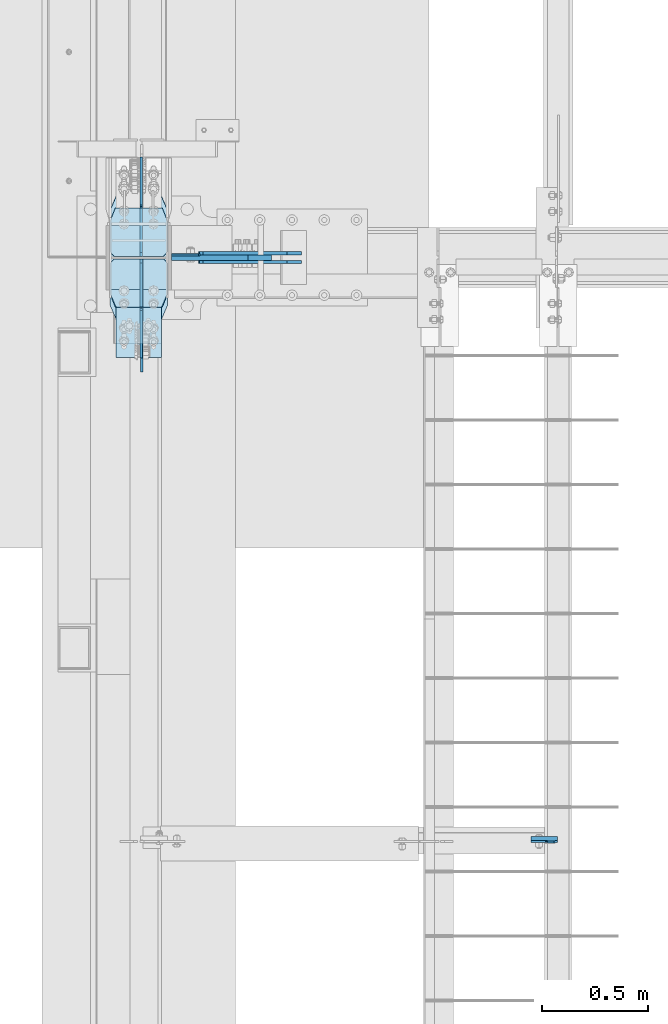
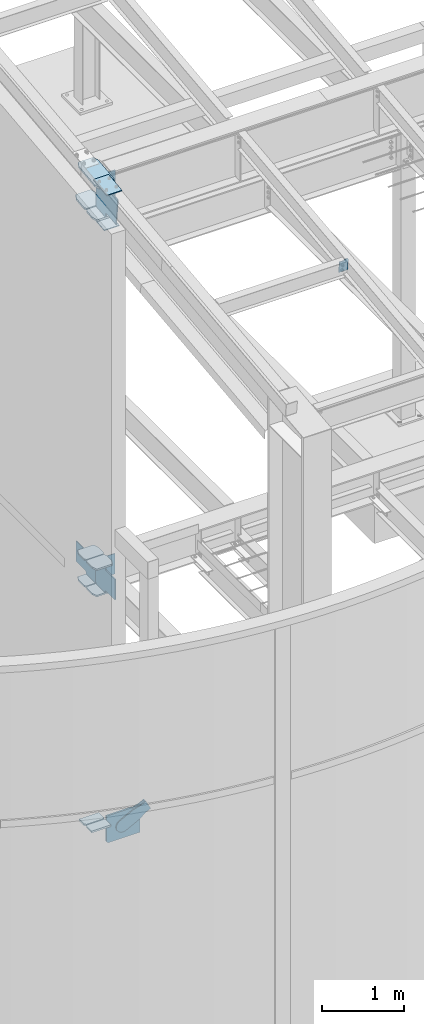
# One storey, part 984 of 1179: 20 plates, 4 elements without a shape of their own.
"""IFC2X3 building model written with IfcOpenShell, lengths in millimetres."""

from ifc_helpers import new_model, si_unit, frame, origin_with_axes, place, context, subcontext, project, spatial, faceted_brep, material, type_object, element, aggregate, save


model = new_model("IFC2X3")

# Units and contexts
model_context = context("Model", 3, precision=1e-05, world=origin_with_axes())
body_context = subcontext(model_context, "Body", "Model", "MODEL_VIEW")
ifc_project = project(units=[si_unit("LENGTHUNIT", "METRE", prefix="MILLI"), si_unit("AREAUNIT", "SQUARE_METRE"), si_unit("VOLUMEUNIT", "CUBIC_METRE"), si_unit("MASSUNIT", "GRAM", prefix="KILO"), si_unit("TIMEUNIT", "SECOND"), si_unit("PLANEANGLEUNIT", "RADIAN"), si_unit("SOLIDANGLEUNIT", "STERADIAN"), si_unit("THERMODYNAMICTEMPERATUREUNIT", "DEGREE_CELSIUS"), si_unit("LUMINOUSINTENSITYUNIT", "LUMEN")], contexts=[model_context])

# Site, building, storey
site_placement = place(None, origin_with_axes())
site = spatial("IfcSite", under=ifc_project, at=site_placement, CompositionType="ELEMENT")
building_placement = place(site_placement, origin_with_axes())
building = spatial("IfcBuilding", under=site, at=building_placement, Name="Undefined", CompositionType="ELEMENT")
storey_placement = place(building_placement, origin_with_axes())
storey = spatial("IfcBuildingStorey", under=building, at=storey_placement, Name="Undefined", CompositionType="ELEMENT", Elevation=0.0)

# Assembly, plate
assembly_1_placement = place(storey_placement, origin_with_axes())
assembly_1 = element("IfcElementAssembly", 1, at=assembly_1_placement, inside=storey, Name="BEAM", AssemblyPlace="NOTDEFINED", PredefinedType="RIGID_FRAME")
ifc_material_1 = material(Name="STEEL/A36")
plate_type_1 = type_object("IfcPlateType", PredefinedType="NOTDEFINED")
plate_1_placement = place(assembly_1_placement, frame((2410.61875, 2674.6330784409, 9544.32257560893), z_axis=(-1.0, 0.0, 0.0), x_axis=(0.0, 0.112284087038014, -0.993676146336441)))
plate_1 = element("IfcPlate", 2, at=plate_1_placement, type_object=plate_type_1, material=ifc_material_1, Name="PLATE", context=body_context, shape_type="Brep", body=[
    faceted_brep([(4.76250032839562, -4.76249999999891, 48.4187500516891), (4.76250032840471, 4.76250000000027, 48.4187500494008), (-1.45519152283669e-11, 4.76249999999345, 48.4187388288169), (-9.09494701772928e-12, -4.76249999999891, 48.4187388288169), (9.62257980372488, -4.76249999999936, 49.3854800144545), (9.62257980373579, 4.76250000000027, 49.3854800121662), (13.7427562245684, -4.76249999999845, 52.1384939244454), (13.7427562245775, 4.76250000000027, 52.1384939221571), (16.4957700889645, -4.76249999999845, 56.2586703757552), (16.4957700889754, 4.76250000000027, 56.2586703734669), (17.4624999979533, -4.76249999999845, 61.118749861791), (17.4624999979624, 4.76250000000073, 61.1187498595027), (17.462499993755, -4.76249999999845, 126.206250000661), (17.4624999937641, 4.76250000000027, 126.206250000003), (15.8749999999891, -4.76249999999845, 0.0), (-1.81898940354586e-12, -4.76249999999936, 15.875), (1.81898940354586e-12, 4.76249999999936, 15.875), (15.8749999999945, 4.76250000000027, 0.0), (185.737499999694, -4.76249999999118, 0.0), (185.737499999699, 4.76250000000755, 0.0), (185.737499999694, -4.76249999999118, 126.206250000003), (185.737499999699, 4.76250000000755, 126.206250000003)], [[[0, 1, 2, 3]], [[4, 5, 1, 0]], [[6, 7, 5, 4]], [[8, 9, 7, 6]], [[10, 11, 9, 8]], [[12, 13, 11, 10]], [[14, 15, 16, 17]], [[18, 14, 17, 19]], [[20, 18, 19, 21]], [[8, 6, 4, 0, 3, 15, 14, 18, 20, 12, 10]], [[16, 15, 3, 2]], [[21, 19, 17, 16, 2, 1, 5, 7, 9, 11, 13]], [[20, 21, 13, 12]]]),
])
aggregate(assembly_1, [plate_1])

# Assembly, plates
assembly_2_placement = place(storey_placement, origin_with_axes())
assembly_2 = element("IfcElementAssembly", 3, at=assembly_2_placement, inside=storey, Name="COLUMN", AssemblyPlace="NOTDEFINED", PredefinedType="RIGID_FRAME")
plate_2_placement = place(assembly_2_placement, frame((587.375000000002, 5446.71250000094, 4051.30000000017), z_axis=(1.0, 0.0, 0.0), x_axis=(0.0, 0.0, -1.0)))
plate_2 = element("IfcPlate", 4, at=plate_2_placement, type_object=plate_type_1, material=ifc_material_1, Name="PLATE", context=body_context, shape_type="Brep", body=[
    faceted_brep([(0.0, -4.76249999999709, 0.0), (0.0, -4.76249999999709, 127.0), (0.0, 4.76249999999709, 127.0), (0.0, 4.76249999999709, 0.0), (304.799999999999, -4.76249999999982, 127.0), (304.799999999999, 4.76249999999982, 127.0), (304.799987792969, -4.76250000000073, 0.0), (304.799987792969, 4.76250000000073, 0.0)], [[[0, 1, 2, 3]], [[2, 1, 4, 5]], [[4, 6, 7, 5]], [[6, 0, 3, 7]], [[5, 7, 3, 2]], [[6, 4, 1, 0]]]),
])
ifc_material_2 = material(Name="STEEL/A572-GR.50")
plate_type_2 = type_object("IfcPlateType", PredefinedType="NOTDEFINED")
plate_3_placement = place(assembly_2_placement, frame((569.912500000002, 5283.99420093539, 137.765030848064), z_axis=(-1.0, 0.0, 0.0), x_axis=(0.0, 1.0, 0.0)))
plate_3 = element("IfcPlate", 5, at=plate_3_placement, type_object=plate_type_2, material=ifc_material_2, Name="PLATE", context=body_context, shape_type="Brep", body=[
    faceted_brep([(0.0, -12.7, 0.0), (-3.81878635380417e-07, -12.7, 276.224999999999), (-3.81878635380417e-07, 12.7, 276.224999999999), (0.0, 12.7, 0.0), (123.824999618709, -12.7000000000002, 276.225000000001), (123.8249996187, 12.6999999999996, 276.225000000001), (146.050000000188, -12.7000000000003, 253.999999618531), (146.050000000178, 12.6999999999995, 253.999999618531), (146.050000000188, -12.7000000000003, 22.2250003814697), (146.050000000178, 12.6999999999995, 22.2250003814697), (123.824999618709, -12.7000000000002, 0.0), (123.8249996187, 12.6999999999996, 0.0)], [[[0, 1, 2, 3]], [[1, 4, 5, 2]], [[4, 6, 7, 5]], [[6, 8, 9, 7]], [[8, 10, 11, 9]], [[10, 0, 3, 11]], [[5, 7, 9, 11, 3, 2]], [[10, 8, 6, 4, 1, 0]]]),
])
plate_4_placement = place(assembly_2_placement, frame((569.912500000002, 5441.15670093552, 137.764887201485), z_axis=(-1.0, 0.0, 0.0), x_axis=(0.0, 1.0, 0.0)))
plate_4 = element("IfcPlate", 6, at=plate_4_placement, type_object=plate_type_2, material=ifc_material_2, Name="PLATE", context=body_context, shape_type="Brep", body=[
    faceted_brep([(4.54747350886464e-12, -12.6999999999999, 22.2250003814697), (4.54747350886464e-12, -12.6999999999999, 253.99999961853), (-4.54747350886464e-12, 12.6999999999999, 253.99999961853), (-4.54747350886464e-12, 12.6999999999999, 22.2250003814697), (22.2250003814834, -12.6999999999999, 276.225), (22.2250003814743, 12.6999999999998, 276.225), (146.050000000188, -12.7000000000003, 276.225), (146.050000000178, 12.6999999999995, 276.225), (146.050000000188, -12.7000000000003, 0.0), (146.050000000178, 12.6999999999995, 0.0), (22.2250003814834, -12.6999999999999, 0.0), (22.2250003814743, 12.6999999999998, 0.0)], [[[0, 1, 2, 3]], [[1, 4, 5, 2]], [[4, 6, 7, 5]], [[6, 8, 9, 7]], [[8, 10, 11, 9]], [[10, 0, 3, 11]], [[5, 7, 9, 11, 3, 2]], [[10, 8, 6, 4, 1, 0]]]),
])
plate_type_3 = type_object("IfcPlateType", PredefinedType="NOTDEFINED")
plate_5_placement = place(assembly_2_placement, frame((295.27500000019, 5142.8082926829, 9813.72370411561), z_axis=(1.0, 0.0, 0.0), x_axis=(0.0, 0.993676357192036, 0.112282221021699)))
plate_5 = element("IfcPlate", 7, at=plate_5_placement, type_object=plate_type_3, material=ifc_material_2, Name="PLATE", context=body_context, shape_type="Brep", body=[
    faceted_brep([(0.0, -14.2875000000004, 30.1625003814697), (0.0, -14.2874999999999, 242.887505722043), (0.0, 14.2874999999999, 242.887505722043), (0.0, 14.2875000000004, 30.1625003814697), (71.4375000016116, -14.2874999999858, 273.049999999798), (71.4375000016071, 14.2874999999967, 273.049999999798), (459.032977177478, -14.2875000000076, 273.049999999762), (459.03297717748, 14.2875000000167, 273.049999999762), (530.470477177256, -14.2875000000058, 242.887499618291), (530.470477177259, 14.2875000000186, 242.887499618291), (530.470477175725, -14.2875000000076, 30.1625003814613), (530.470477175728, 14.2875000000167, 30.1625003814613), (459.032977175513, -14.2875000000058, -7.27595761418343e-12), (459.032977175516, 14.2875000000167, -7.27595761418343e-12), (71.43750000002, -14.287499999984, 2.90469870378729e-11), (71.4375000000155, 14.2874999999949, 2.90469870378729e-11)], [[[0, 1, 2, 3]], [[1, 4, 5, 2]], [[4, 6, 7, 5]], [[6, 8, 9, 7]], [[8, 10, 11, 9]], [[10, 12, 13, 11]], [[12, 14, 15, 13]], [[14, 0, 3, 15]], [[5, 7, 9, 11, 13, 15, 3, 2]], [[14, 12, 10, 8, 6, 4, 1, 0]]]),
])
plate_6_placement = place(assembly_2_placement, frame((568.32499999993, 5728.41082930927, 9355.69981078858), z_axis=(-1.0, 0.0, 0.0), x_axis=(0.0, -0.993676146336441, -0.112284087038017)))
plate_6 = element("IfcPlate", 8, at=plate_6_placement, type_object=plate_type_3, material=ifc_material_2, Name="PLATE", context=body_context, shape_type="Brep", body=[
    faceted_brep([(0.0, -14.2875000000004, 30.1625003814697), (0.0, -14.2874999999999, 242.887505722043), (0.0, 14.2874999999999, 242.887505722043), (0.0, 14.2875000000004, 30.1625003814697), (71.4375000016116, -14.2874999999858, 273.049999999798), (71.4375000016071, 14.2874999999967, 273.049999999798), (265.234311050795, -14.2874999998585, 273.049999999967), (265.234311050809, 14.2875000001295, 273.049999999967), (287.459311432365, -14.2874999998457, 250.824999618502), (287.45931143238, 14.2875000001404, 250.824999618502), (287.459311433311, -14.2874999998457, 22.2250003815391), (287.459311433325, 14.2875000001404, 22.2250003815391), (265.234311051926, -14.2874999998585, 6.40056896372698e-11), (265.23431105194, 14.2875000001295, 6.40056896372698e-11), (71.43750000002, -14.287499999984, 2.90469870378729e-11), (71.4375000000155, 14.2874999999949, 2.90469870378729e-11)], [[[0, 1, 2, 3]], [[1, 4, 5, 2]], [[4, 6, 7, 5]], [[6, 8, 9, 7]], [[8, 10, 11, 9]], [[10, 12, 13, 11]], [[12, 14, 15, 13]], [[14, 0, 3, 15]], [[5, 7, 9, 11, 13, 15, 3, 2]], [[14, 12, 10, 8, 6, 4, 1, 0]]]),
])
plate_type_4 = type_object("IfcPlateType", PredefinedType="NOTDEFINED")
plate_7_placement = place(assembly_2_placement, frame((295.275000000002, 5201.44744418182, 3697.287499994), z_axis=(1.0, 0.0, 0.0), x_axis=(0.0, 1.0, 0.0)))
plate_7 = element("IfcPlate", 9, at=plate_7_placement, type_object=plate_type_4, material=ifc_material_2, Name="PLATE", context=body_context, shape_type="Brep", body=[
    faceted_brep([(0.0, -11.1125000000002, 247.650000381473), (63.5, -11.1125000000002, 273.050000000003), (63.5, 11.1125000000002, 273.050000000003), (0.0, 11.1125000000002, 247.650000381473), (63.5, -11.1125000000002, 0.0), (0.0, -11.1125000000002, 25.3999996185303), (0.0, 11.1125000000002, 25.3999996185303), (63.5, 11.1125000000002, 0.0), (206.374999618529, -11.1125000000002, 0.0), (206.374999618529, 11.1125000000002, 0.0), (228.599999999999, -11.1125000000002, 22.2250003814697), (228.599999999999, 11.1125000000002, 22.2250003814697), (228.599999999999, -11.1125000000002, 250.824999618533), (228.599999999999, 11.1125000000002, 250.824999618533), (206.374999618529, -11.1125000000002, 273.050000000003), (206.374999618529, 11.1125000000002, 273.050000000003)], [[[0, 1, 2, 3]], [[4, 5, 6, 7]], [[8, 4, 7, 9]], [[10, 8, 9, 11]], [[12, 10, 11, 13]], [[14, 12, 13, 15]], [[4, 8, 10, 12, 14, 1, 0, 5]], [[5, 0, 3, 6]], [[2, 15, 13, 11, 9, 7, 6, 3]], [[1, 14, 15, 2]]]),
])
plate_8_placement = place(assembly_2_placement, frame((295.275000000001, 5201.44780402344, 4090.98749999399), z_axis=(1.0, 0.0, 0.0), x_axis=(0.0, 1.0, 0.0)))
plate_8 = element("IfcPlate", 10, at=plate_8_placement, type_object=plate_type_4, material=ifc_material_2, Name="PLATE", context=body_context, shape_type="Brep", body=[
    faceted_brep([(0.0, -11.1125000000002, 247.650000381473), (63.5, -11.1125000000002, 273.050000000003), (63.5, 11.1125000000002, 273.050000000003), (0.0, 11.1125000000002, 247.650000381473), (63.5, -11.1125000000002, 0.0), (0.0, -11.1125000000002, 25.3999996185303), (0.0, 11.1125000000002, 25.3999996185303), (63.5, 11.1125000000002, 0.0), (206.374999618529, -11.1125000000002, 0.0), (206.374999618529, 11.1125000000002, 0.0), (228.599999999999, -11.1125000000002, 22.2250003814697), (228.599999999999, 11.1125000000002, 22.2250003814697), (228.599999999999, -11.1125000000002, 250.824999618533), (228.599999999999, 11.1125000000002, 250.824999618533), (206.374999618529, -11.1125000000002, 273.050000000003), (206.374999618529, 11.1125000000002, 273.050000000003)], [[[0, 1, 2, 3]], [[4, 5, 6, 7]], [[8, 4, 7, 9]], [[10, 8, 9, 11]], [[12, 10, 11, 13]], [[14, 12, 13, 15]], [[4, 8, 10, 12, 14, 1, 0, 5]], [[5, 0, 3, 6]], [[2, 15, 13, 11, 9, 7, 6, 3]], [[1, 14, 15, 2]]]),
])
plate_9_placement = place(assembly_2_placement, frame((568.324999999997, 5669.75996159354, 3694.1124999953), z_axis=(-1.0, 0.0, 0.0), x_axis=(0.0, -1.0, 0.0)))
plate_9 = element("IfcPlate", 11, at=plate_9_placement, type_object=plate_type_4, material=ifc_material_2, Name="PLATE", context=body_context, shape_type="Brep", body=[
    faceted_brep([(0.0, -11.1125000000002, 247.650000381473), (63.5, -11.1125000000002, 273.050000000003), (63.5, 11.1125000000002, 273.050000000003), (0.0, 11.1125000000002, 247.650000381473), (63.5, -11.1125000000002, 0.0), (0.0, -11.1125000000002, 25.3999996185303), (0.0, 11.1125000000002, 25.3999996185303), (63.5, 11.1125000000002, 0.0), (206.374999618529, -11.1125000000002, 0.0), (206.374999618529, 11.1125000000002, 0.0), (228.599999999999, -11.1125000000002, 22.2250003814697), (228.599999999999, 11.1125000000002, 22.2250003814697), (228.599999999999, -11.1125000000002, 250.824999618533), (228.599999999999, 11.1125000000002, 250.824999618533), (206.374999618529, -11.1125000000002, 273.050000000003), (206.374999618529, 11.1125000000002, 273.050000000003)], [[[0, 1, 2, 3]], [[4, 5, 6, 7]], [[8, 4, 7, 9]], [[10, 8, 9, 11]], [[12, 10, 11, 13]], [[14, 12, 13, 15]], [[4, 8, 10, 12, 14, 1, 0, 5]], [[5, 0, 3, 6]], [[2, 15, 13, 11, 9, 7, 6, 3]], [[1, 14, 15, 2]]]),
])
plate_10_placement = place(assembly_2_placement, frame((568.324999999997, 5669.76032433706, 4090.98749999505), z_axis=(-1.0, 0.0, 0.0), x_axis=(0.0, -1.0, 0.0)))
plate_10 = element("IfcPlate", 12, at=plate_10_placement, type_object=plate_type_4, material=ifc_material_2, Name="PLATE", context=body_context, shape_type="Brep", body=[
    faceted_brep([(0.0, -11.1125000000002, 247.650000381473), (63.5, -11.1125000000002, 273.050000000003), (63.5, 11.1125000000002, 273.050000000003), (0.0, 11.1125000000002, 247.650000381473), (63.5, -11.1125000000002, 0.0), (0.0, -11.1125000000002, 25.3999996185303), (0.0, 11.1125000000002, 25.3999996185303), (63.5, 11.1125000000002, 0.0), (206.374999618529, -11.1125000000002, 0.0), (206.374999618529, 11.1125000000002, 0.0), (228.599999999999, -11.1125000000002, 22.2250003814697), (228.599999999999, 11.1125000000002, 22.2250003814697), (228.599999999999, -11.1125000000002, 250.824999618533), (228.599999999999, 11.1125000000002, 250.824999618533), (206.374999618529, -11.1125000000002, 273.050000000003), (206.374999618529, 11.1125000000002, 273.050000000003)], [[[0, 1, 2, 3]], [[4, 5, 6, 7]], [[8, 4, 7, 9]], [[10, 8, 9, 11]], [[12, 10, 11, 13]], [[14, 12, 13, 15]], [[4, 8, 10, 12, 14, 1, 0, 5]], [[5, 0, 3, 6]], [[2, 15, 13, 11, 9, 7, 6, 3]], [[1, 14, 15, 2]]]),
])
plate_type_5 = type_object("IfcPlateType", PredefinedType="NOTDEFINED")
plate_11_placement = place(assembly_2_placement, frame((587.375357187497, 5448.30641762517, 9769.76628314442), z_axis=(1.0, 0.0, 0.0), x_axis=(0.0, 0.0, -1.0)))
plate_11 = element("IfcPlate", 13, at=plate_11_placement, type_object=plate_type_5, material=ifc_material_1, Name="PLATE", context=body_context, shape_type="Brep", body=[
    faceted_brep([(0.0, -6.34999999999854, 0.0), (0.0, -6.34999999999854, 133.350000000002), (0.0, 6.34999999999854, 133.350000000002), (0.0, 6.34999999999854, 0.0), (622.300000000001, -6.35000000000036, 133.350000000001), (622.300000000001, 6.35000000000036, 133.350000000001), (622.300000000001, -6.35000000000036, 0.0), (622.300000000001, 6.35000000000036, 0.0)], [[[0, 1, 2, 3]], [[1, 4, 5, 2]], [[4, 6, 7, 5]], [[6, 0, 3, 7]], [[5, 7, 3, 2]], [[6, 4, 1, 0]]]),
])
plate_type_6 = type_object("IfcPlateType", PredefinedType="NOTDEFINED")
plate_12_placement = place(assembly_2_placement, frame((323.850003068444, 4964.6084850364, 9814.28553889934), z_axis=(1.0, 0.0, 0.0), x_axis=(0.0, 0.993676146336441, 0.112284087038017)))
plate_12 = element("IfcPlate", 14, at=plate_12_placement, type_object=plate_type_6, material=ifc_material_2, Name="PLATE", context=body_context, shape_type="Brep", body=[
    faceted_brep([(0.0, -6.34999999999854, 0.0), (0.0, -6.350000000004, 215.899993896484), (0.0, 6.35000000000582, 215.899993896484), (0.0, 6.34999999999854, 0.0), (330.200000001782, -6.34999999994034, 215.899993896483), (330.200000001782, 6.35000000006767, 215.899993896483), (330.200000001782, -6.34999999994034, -1.47792889038101e-12), (330.200000001782, 6.35000000006767, -1.47792889038101e-12)], [[[0, 1, 2, 3]], [[1, 4, 5, 2]], [[4, 6, 7, 5]], [[6, 0, 3, 7]], [[5, 7, 3, 2]], [[6, 4, 1, 0]]]),
])
plate_13_placement = place(assembly_2_placement, frame((323.850003041494, 5026.9343627406, 9255.76748326321), z_axis=(1.0, 0.0, 0.0), x_axis=(0.0, 0.993676146336441, 0.112284087038017)))
plate_13 = element("IfcPlate", 15, at=plate_13_placement, type_object=plate_type_6, material=ifc_material_2, Name="PLATE", context=body_context, shape_type="Brep", body=[
    faceted_brep([(0.0, -6.34999999999854, 0.0), (0.0, -6.350000000004, 215.899993896484), (0.0, 6.35000000000582, 215.899993896484), (0.0, 6.34999999999854, 0.0), (330.200000001782, -6.34999999994034, 215.899993896483), (330.200000001782, 6.35000000006767, 215.899993896483), (330.200000001782, -6.34999999994034, -1.47792889038101e-12), (330.200000001782, 6.35000000006767, -1.47792889038101e-12)], [[[0, 1, 2, 3]], [[1, 4, 5, 2]], [[4, 6, 7, 5]], [[6, 0, 3, 7]], [[5, 7, 3, 2]], [[6, 4, 1, 0]]]),
])
plate_type_7 = type_object("IfcPlateType", PredefinedType="NOTDEFINED")
plate_14_placement = place(assembly_2_placement, frame((295.275000000183, 5201.29393468393, 9296.1368665814), z_axis=(1.0, 0.0, 0.0), x_axis=(0.0, 0.993676357192036, 0.112282221021699)))
plate_14 = element("IfcPlate", 16, at=plate_14_placement, type_object=plate_type_7, material=ifc_material_2, Name="PLATE", context=body_context, shape_type="Brep", body=[
    faceted_brep([(0.0, -14.2875000000004, 30.1625003814697), (0.0, -14.2874999999999, 242.887505722043), (0.0, 14.2874999999999, 242.887505722043), (0.0, 14.2875000000004, 30.1625003814697), (71.4375000016116, -14.2874999999858, 273.049999999798), (71.4375000016071, 14.2874999999967, 273.049999999798), (206.374999620103, -14.2874999999731, 273.049999999853), (206.374999620097, 14.2875000000076, 273.049999999853), (228.600000001447, -14.2874999999713, 250.824999618393), (228.600000001442, 14.2875000000113, 250.824999618393), (228.600000000114, -14.2874999999713, 22.2250003815627), (228.600000000108, 14.2875000000095, 22.2250003815627), (206.37499961851, -14.2874999999731, 8.39008862385526e-11), (206.374999618503, 14.2875000000095, 8.39008862385526e-11), (71.43750000002, -14.287499999984, 2.90469870378729e-11), (71.4375000000155, 14.2874999999949, 2.90469870378729e-11)], [[[0, 1, 2, 3]], [[1, 4, 5, 2]], [[4, 6, 7, 5]], [[6, 8, 9, 7]], [[8, 10, 11, 9]], [[10, 12, 13, 11]], [[12, 14, 15, 13]], [[14, 0, 3, 15]], [[5, 7, 9, 11, 13, 15, 3, 2]], [[14, 12, 10, 8, 6, 4, 1, 0]]]),
])
plate_type_8 = type_object("IfcPlateType", PredefinedType="NOTDEFINED")
plate_15_placement = place(assembly_2_placement, frame((445.293750000002, 5429.95555027375, 9355.40331321051), z_axis=(0.0, -0.743857530975871, 0.668338217978353), x_axis=(0.0, -0.668338217978354, -0.743857530975871)))
plate_15 = element("IfcPlate", 17, at=plate_15_placement, type_object=plate_type_8, material=ifc_material_2, Name="PLATE", context=body_context, shape_type="Brep", body=[
    faceted_brep([(-340.375214000167, -6.35000000000002, 305.818434893387), (-340.053041236401, -6.35000000000002, 331.102415037907), (-340.053041236401, 6.35000000000002, 331.102415037907), (-340.375214000167, 6.35000000000002, 305.818434893387), (0.0, -6.34999999999854, 0.0), (0.0, 6.34999999999854, 0.0), (28.5035613092805, -6.35000000000002, -1.04591890703887e-11), (28.5035613092805, 6.35000000000002, -1.04591890703887e-11), (187.420601399348, -6.35000000000002, 141.163452271464), (187.420601399348, 6.35000000000002, 141.163452271464), (153.121511960926, -6.35000000000002, 179.776207060837), (153.121511960926, 6.35000000000002, 179.776207060837), (148.111828553017, -6.35000000000002, 188.327179091378), (148.111828553017, 6.35000000000002, 188.327179091378), (146.755726190504, -6.35000000000002, 198.144359791408), (146.755726190504, 6.35000000000002, 198.144359791408), (149.259651370594, -6.35000000000002, 207.733228817898), (149.259651370594, 6.35000000000002, 207.733228817898), (155.242418574415, -6.35000000000002, 215.634022898216), (155.242418574415, 6.35000000000002, 215.634022898216), (325.556754792438, -6.35000000000002, 366.930663323459), (325.556754792438, 6.35000000000002, 366.930663323459), (63.9881057059411, -6.35000000000002, 661.395801413212), (63.9881057059411, 6.35000000000002, 661.395801413212), (-108.439216406068, -6.35000000000002, 508.020105830638), (-108.439216406068, 6.35000000000002, 508.020105830638), (-115.988873387907, -6.35000000000002, 503.591015810325), (-115.988873387907, 6.35000000000002, 503.591015810325), (-124.658991855624, -6.35000000000002, 502.389681257769), (-124.658991855624, 6.35000000000002, 502.389681257769), (-133.128490026194, -6.35000000000002, 504.599151712447), (-133.128490026194, 6.35000000000002, 504.599151712447), (-139.394780873125, -6.35000000000002, 509.343624777056), (-139.525108848715, -6.35000000000002, 509.227856713423), (-139.525108848715, 6.35000000000002, 509.227856713423), (-139.394780873125, 6.35000000000002, 509.343624777056)], [[[0, 1, 2, 3]], [[4, 0, 3, 5]], [[6, 4, 5, 7]], [[8, 6, 7, 9]], [[10, 8, 9, 11]], [[12, 10, 11, 13]], [[14, 12, 13, 15]], [[16, 14, 15, 17]], [[18, 16, 17, 19]], [[20, 18, 19, 21]], [[22, 20, 21, 23]], [[24, 22, 23, 25]], [[26, 24, 25, 27]], [[28, 26, 27, 29]], [[30, 28, 29, 31]], [[1, 0, 4, 6, 8, 10, 12, 14, 16, 18, 20, 22, 24, 26, 28, 30, 32, 33]], [[1, 33, 34, 2]], [[31, 29, 27, 25, 23, 21, 19, 17, 15, 13, 11, 9, 7, 5, 3, 2, 34, 35]], [[30, 31, 35, 32]], [[34, 33, 32, 35]]]),
])

# Assembly, plate
assembly_3_placement = place(storey_placement, origin_with_axes())
assembly_3 = element("IfcElementAssembly", 18, at=assembly_3_placement, inside=storey, AssemblyPlace="NOTDEFINED", PredefinedType="RIGID_FRAME")
plate_type_9 = type_object("IfcPlateType", PredefinedType="NOTDEFINED")
plate_16_placement = place(assembly_3_placement, frame((1127.36545388962, 5456.2375, 63.2880253348642), z_axis=(-0.461652125829643, 0.0, 0.88706105467266), x_axis=(0.88706105467266, 0.0, 0.461652125829643)))
plate_16 = element("IfcPlate", 19, at=plate_16_placement, type_object=plate_type_9, material=ifc_material_1, context=body_context, shape_type="Brep", body=[
    faceted_brep([(0.0, -7.9375, 0.0), (-101.600000000497, -7.9375, -21.7975798445477), (-101.600000000497, 7.9375, -21.7975798445477), (0.0, 7.9375, 0.0), (-320.921138851689, -7.9375, -21.7975798443877), (-320.921138851689, 7.9375, -21.7975798443877), (-357.371735784433, -7.9375, -14.5471053160727), (-357.371735784433, 7.9375, -14.5471053160727), (-388.273059759649, -7.9375, 6.10049924760824), (-388.273059759649, 7.9375, 6.10049924760824), (-408.920664323319, -7.9375, 37.0018232228431), (-408.920664323319, 7.9375, 37.0018232228431), (-416.171138851623, -7.9375, 73.4524201546446), (-416.171138851623, 7.9375, 73.4524201546446), (-408.920664323337, -7.9375, 109.903017087447), (-408.920664323337, 7.9375, 109.903017087447), (-388.273059759656, -7.9375, 140.804341062707), (-388.273059759656, 7.9375, 140.804341062707), (-357.3717357844, -7.9375, 161.451945626395), (-357.3717357844, 7.9375, 161.451945626395), (-320.921138851201, -7.9375, 168.702420154674), (-320.921138851201, 7.9375, 168.702420154674), (-101.600000000592, -7.9375, 168.702420154521), (-101.600000000592, 7.9375, 168.702420154521), (-8.00355337560177e-11, -7.9375, 146.904840309817), (-8.00355337560177e-11, 7.9375, 146.904840309817), (82.5499999998137, -7.9375, 146.90484031055), (82.5499999998137, 7.9375, 146.90484031055), (82.5500000000975, -7.9375, -6.91215973347425e-11), (82.5500000000975, 7.9375, -6.91215973347425e-11)], [[[0, 1, 2, 3]], [[1, 4, 5, 2]], [[4, 6, 7, 5]], [[6, 8, 9, 7]], [[8, 10, 11, 9]], [[10, 12, 13, 11]], [[12, 14, 15, 13]], [[14, 16, 17, 15]], [[16, 18, 19, 17]], [[18, 20, 21, 19]], [[20, 22, 23, 21]], [[22, 24, 25, 23]], [[24, 26, 27, 25]], [[26, 28, 29, 27]], [[28, 0, 3, 29]], [[5, 7, 9, 11, 13, 15, 17, 19, 21, 23, 25, 27, 29, 3, 2]], [[28, 26, 24, 22, 20, 18, 16, 14, 12, 10, 8, 6, 4, 1, 0]]]),
])
aggregate(assembly_3, [plate_16])

assembly_4_placement = place(storey_placement, origin_with_axes())
assembly_4 = element("IfcElementAssembly", 20, at=assembly_4_placement, inside=storey, AssemblyPlace="NOTDEFINED", PredefinedType="RIGID_FRAME")
plate_17_placement = place(assembly_4_placement, frame((1127.36545388962, 5414.9625, 63.2880253348642), z_axis=(-0.461652125829643, 0.0, 0.88706105467266), x_axis=(0.88706105467266, 0.0, 0.461652125829643)))
plate_17 = element("IfcPlate", 21, at=plate_17_placement, type_object=plate_type_9, material=ifc_material_1, context=body_context, shape_type="Brep", body=[
    faceted_brep([(0.0, -7.9375, 0.0), (-101.600000000497, -7.9375, -21.7975798445477), (-101.600000000497, 7.9375, -21.7975798445477), (0.0, 7.9375, 0.0), (-320.921138851689, -7.9375, -21.7975798443877), (-320.921138851689, 7.9375, -21.7975798443877), (-357.371735784433, -7.9375, -14.5471053160727), (-357.371735784433, 7.9375, -14.5471053160727), (-388.273059759649, -7.9375, 6.10049924760824), (-388.273059759649, 7.9375, 6.10049924760824), (-408.920664323319, -7.9375, 37.0018232228431), (-408.920664323319, 7.9375, 37.0018232228431), (-416.171138851623, -7.9375, 73.4524201546446), (-416.171138851623, 7.9375, 73.4524201546446), (-408.920664323337, -7.9375, 109.903017087447), (-408.920664323337, 7.9375, 109.903017087447), (-388.273059759656, -7.9375, 140.804341062707), (-388.273059759656, 7.9375, 140.804341062707), (-357.3717357844, -7.9375, 161.451945626395), (-357.3717357844, 7.9375, 161.451945626395), (-320.921138851201, -7.9375, 168.702420154674), (-320.921138851201, 7.9375, 168.702420154674), (-101.600000000592, -7.9375, 168.702420154521), (-101.600000000592, 7.9375, 168.702420154521), (-8.00355337560177e-11, -7.9375, 146.904840309817), (-8.00355337560177e-11, 7.9375, 146.904840309817), (82.5499999998137, -7.9375, 146.90484031055), (82.5499999998137, 7.9375, 146.90484031055), (82.5500000000975, -7.9375, -6.91215973347425e-11), (82.5500000000975, 7.9375, -6.91215973347425e-11)], [[[0, 1, 2, 3]], [[1, 4, 5, 2]], [[4, 6, 7, 5]], [[6, 8, 9, 7]], [[8, 10, 11, 9]], [[10, 12, 13, 11]], [[12, 14, 15, 13]], [[14, 16, 17, 15]], [[16, 18, 19, 17]], [[18, 20, 21, 19]], [[20, 22, 23, 21]], [[22, 24, 25, 23]], [[24, 26, 27, 25]], [[26, 28, 29, 27]], [[28, 0, 3, 29]], [[5, 7, 9, 11, 13, 15, 17, 19, 21, 23, 25, 27, 29, 3, 2]], [[28, 26, 24, 22, 20, 18, 16, 14, 12, 10, 8, 6, 4, 1, 0]]]),
])
aggregate(assembly_4, [plate_17])

# Plate
plate_type_10 = type_object("IfcPlateType", PredefinedType="NOTDEFINED")
plate_18_placement = place(assembly_2_placement, frame((587.375000000002, 5435.60013058058, -215.9), z_axis=(0.0, 0.0, 1.0), x_axis=(1.0, 0.0, 0.0)))
plate_18 = element("IfcPlate", 22, at=plate_18_placement, type_object=plate_type_10, material=ifc_material_2, Name="PLATE", context=body_context, shape_type="Brep", body=[
    faceted_brep([(0.0, -12.7000000000007, 19.0500000000029), (0.0, -12.6999999999998, 404.464866888042), (0.0, 12.6999999999998, 404.464866888042), (0.0, 12.7000000000007, 19.0500000000029), (360.257255841574, -12.6999999999998, 404.464866888021), (360.257255841574, 12.6999999999998, 404.464866888021), (471.653913804267, -12.6999999999998, 190.417034395508), (471.653913804267, 12.6999999999998, 190.417034395508), (471.653913804267, -12.6999999999998, 2.8421709430404e-14), (471.653913804267, 12.6999999999998, 2.8421709430404e-14), (19.0499992370605, -12.6999999999971, 0.0), (19.0499992370605, 12.6999999999971, 0.0)], [[[0, 1, 2, 3]], [[1, 4, 5, 2]], [[4, 6, 7, 5]], [[6, 8, 9, 7]], [[8, 10, 11, 9]], [[10, 0, 3, 11]], [[5, 7, 9, 11, 3, 2]], [[10, 8, 6, 4, 1, 0]]]),
])

plate_type_11 = type_object("IfcPlateType", PredefinedType="NOTDEFINED")
plate_19_placement = place(assembly_2_placement, frame((443.706250000002, 5430.04741179173, 3727.44999999151), z_axis=(0.0, -0.707106781186506, 0.707106781186589), x_axis=(0.0, -0.70710678118659, -0.707106781186505)))
plate_19 = element("IfcPlate", 23, at=plate_19_placement, type_object=plate_type_11, material=ifc_material_2, Name="PLATE", context=body_context, shape_type="Brep", body=[
    faceted_brep([(0.0, -6.34999999999854, 0.0), (-235.731830903293, -6.35000000000002, 235.731615453129), (-235.731830903293, 6.35000000000002, 235.731615453129), (0.0, 6.34999999999854, 0.0), (-235.731830903261, -6.35000000000002, 262.672371504901), (-235.731830903261, 6.35000000000002, 262.672371504901), (-88.1191215129029, -6.35000000000002, 410.284945982362), (-88.1191215129029, 6.35000000000002, 410.284945982362), (-85.8740474659135, -6.35000000000002, 408.039873987286), (-85.8740474659135, 6.35000000000002, 408.039873987286), (-77.6336920134536, -6.35000000000002, 402.533849952023), (-77.6336920134536, 6.35000000000002, 402.533849952023), (-67.9135320938085, -6.35000000000002, 400.600394548784), (-67.9135320938085, 6.35000000000002, 400.600394548784), (-58.1933739412743, -6.35000000000002, 402.533858835898), (-58.1933739412743, 6.35000000000002, 402.533858835898), (-49.9530235211214, -6.35000000000002, 408.039890402549), (-49.9530235211214, 6.35000000000002, 408.039890402549), (103.272773494093, -6.35000000000002, 561.265827460693), (103.272773494093, 6.35000000000002, 561.265827460693), (318.799018891273, -6.35000000000002, 345.739779046518), (318.799018891273, 6.35000000000002, 345.739779046518), (165.573221876059, -6.35000000000002, 192.513841988374), (165.573221876059, 6.35000000000002, 192.513841988374), (160.067197840795, -6.35000000000002, 184.27348653591), (160.067197840795, 6.35000000000002, 184.27348653591), (158.133742437553, -6.35000000000002, 174.55332661626), (158.133742437553, 6.35000000000002, 174.55332661626), (160.067206724663, -6.35000000000002, 164.833168463723), (160.067206724663, 6.35000000000002, 164.833168463723), (165.573238291309, -6.35000000000002, 156.592818043571), (165.573238291309, 6.35000000000002, 156.592818043571), (174.553490065037, -6.35000000000002, 147.612574477461), (174.553490065037, 6.35000000000002, 147.612574477461), (26.9407683631471, -6.34999999999854, -6.91215973347425e-11), (26.9407683631471, 6.34999999999854, -6.91215973347425e-11)], [[[0, 1, 2, 3]], [[1, 4, 5, 2]], [[4, 6, 7, 5]], [[6, 8, 9, 7]], [[8, 10, 11, 9]], [[10, 12, 13, 11]], [[12, 14, 15, 13]], [[14, 16, 17, 15]], [[16, 18, 19, 17]], [[18, 20, 21, 19]], [[20, 22, 23, 21]], [[22, 24, 25, 23]], [[24, 26, 27, 25]], [[26, 28, 29, 27]], [[28, 30, 31, 29]], [[30, 32, 33, 31]], [[32, 34, 35, 33]], [[34, 0, 3, 35]], [[5, 7, 9, 11, 13, 15, 17, 19, 21, 23, 25, 27, 29, 31, 33, 35, 3, 2]], [[34, 32, 30, 28, 26, 24, 22, 20, 18, 16, 14, 12, 10, 8, 6, 4, 1, 0]]]),
])

plate_type_12 = type_object("IfcPlateType", PredefinedType="NOTDEFINED")
plate_20_placement = place(assembly_2_placement, frame((443.706250000002, 5441.15997901061, 3724.27499998076), z_axis=(0.0, 0.707106781186542, 0.707106781186553), x_axis=(0.0, 0.707106781186553, -0.707106781186542)))
plate_20 = element("IfcPlate", 24, at=plate_20_placement, type_object=plate_type_12, material=ifc_material_2, Name="PLATE", context=body_context, shape_type="Brep", body=[
    faceted_brep([(0.0, -6.34999999999854, 0.0), (-237.976787208419, -6.34999999999854, 237.976787208414), (-237.976787208419, 6.34999999999854, 237.976787208414), (0.0, 6.34999999999854, 0.0), (-237.976787208489, -6.34999999999854, 264.917555571561), (-237.976787208489, 6.34999999999854, 264.917555571561), (-90.3638272187129, -6.35000000000002, 412.530515561223), (-90.3638272187129, 6.35000000000002, 412.530515561223), (-88.1187629187018, -6.35000000000002, 410.285451261215), (-88.1187629187018, 6.35000000000002, 410.285451261215), (-79.8784099823927, -6.35000000000002, 404.779423460262), (-79.8784099823927, 6.35000000000002, 404.779423460262), (-70.1582509462989, -6.35000000000002, 402.845963615088), (-70.1582509462989, 6.35000000000002, 402.845963615088), (-60.4380919102052, -6.35000000000002, 404.779423460268), (-60.4380919102052, 6.35000000000002, 404.779423460268), (-52.1977389738952, -6.35000000000002, 410.285451261226), (-52.1977389738952, 6.35000000000002, 410.285451261226), (100.46661535365, -6.35000000000002, 562.949805588772), (100.46661535365, 6.35000000000002, 562.949805588772), (315.992762259406, -6.35000000000002, 347.423658683155), (315.992762259406, 6.35000000000002, 347.423658683155), (163.32840793186, -6.35000000000002, 194.759304355609), (163.32840793186, 6.35000000000002, 194.759304355609), (157.822380130903, -6.35000000000002, 186.5189514193), (157.822380130903, 6.35000000000002, 186.5189514193), (155.888920285727, -6.35000000000002, 176.798792383209), (155.888920285727, 6.35000000000002, 176.798792383209), (157.822380130903, -6.35000000000002, 167.07863334712), (157.822380130903, 6.35000000000002, 167.07863334712), (163.32840793186, -6.35000000000002, 158.838280410814), (163.32840793186, 6.35000000000002, 158.838280410814), (174.553728352508, -6.34999999999854, 147.612959989299), (174.553728352508, 6.34999999999854, 147.612959989299), (26.9407683631471, -6.34999999999854, -6.91215973347425e-11), (26.9407683631471, 6.34999999999854, -6.91215973347425e-11)], [[[0, 1, 2, 3]], [[1, 4, 5, 2]], [[4, 6, 7, 5]], [[6, 8, 9, 7]], [[8, 10, 11, 9]], [[10, 12, 13, 11]], [[12, 14, 15, 13]], [[14, 16, 17, 15]], [[16, 18, 19, 17]], [[18, 20, 21, 19]], [[20, 22, 23, 21]], [[22, 24, 25, 23]], [[24, 26, 27, 25]], [[26, 28, 29, 27]], [[28, 30, 31, 29]], [[30, 32, 33, 31]], [[32, 34, 35, 33]], [[34, 0, 3, 35]], [[5, 7, 9, 11, 13, 15, 17, 19, 21, 23, 25, 27, 29, 31, 33, 35, 3, 2]], [[34, 32, 30, 28, 26, 24, 22, 20, 18, 16, 14, 12, 10, 8, 6, 4, 1, 0]]]),
])

aggregate(assembly_2, [plate_3, plate_4, plate_11, plate_12, plate_13, plate_14, plate_5, plate_15, plate_6, plate_18, plate_7, plate_8, plate_19, plate_9, plate_10, plate_20, plate_2])

save(model, "model.ifc")
